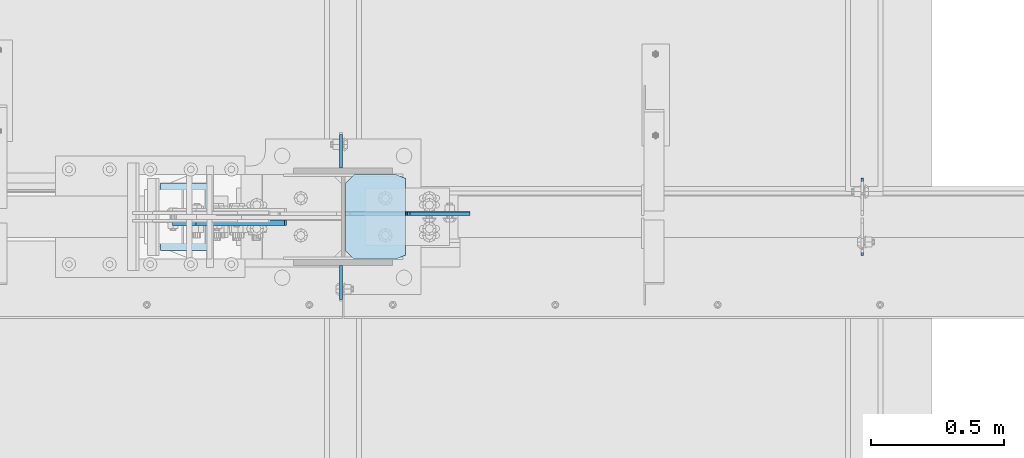
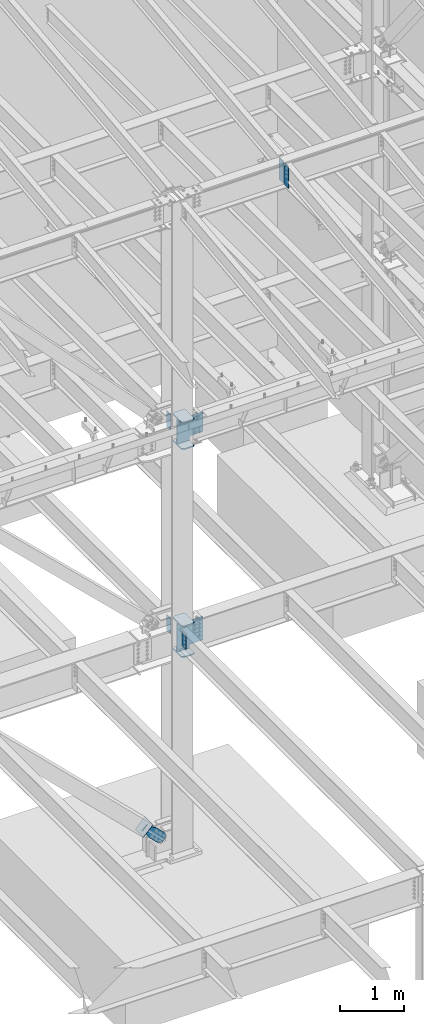
# One storey, part 1042 of 1179: 13 plates, 4 elements without a shape of their own.
"""IFC2X3 building model written with IfcOpenShell, lengths in millimetres."""

from ifc_helpers import new_model, si_unit, frame, origin_with_axes, place, context, subcontext, project, spatial, faceted_brep, material, type_object, element, aggregate, save


model = new_model("IFC2X3")

# Units and contexts
model_context = context("Model", 3, precision=1e-05, world=origin_with_axes())
body_context = subcontext(model_context, "Body", "Model", "MODEL_VIEW")
ifc_project = project(units=[si_unit("LENGTHUNIT", "METRE", prefix="MILLI"), si_unit("AREAUNIT", "SQUARE_METRE"), si_unit("VOLUMEUNIT", "CUBIC_METRE"), si_unit("MASSUNIT", "GRAM", prefix="KILO"), si_unit("TIMEUNIT", "SECOND"), si_unit("PLANEANGLEUNIT", "RADIAN"), si_unit("SOLIDANGLEUNIT", "STERADIAN"), si_unit("THERMODYNAMICTEMPERATUREUNIT", "DEGREE_CELSIUS"), si_unit("LUMINOUSINTENSITYUNIT", "LUMEN")], contexts=[model_context])

# Site, building, storey
site_placement = place(None, origin_with_axes())
site = spatial("IfcSite", under=ifc_project, at=site_placement, CompositionType="ELEMENT")
building_placement = place(site_placement, origin_with_axes())
building = spatial("IfcBuilding", under=site, at=building_placement, Name="Undefined", CompositionType="ELEMENT")
storey_placement = place(building_placement, origin_with_axes())
storey = spatial("IfcBuildingStorey", under=building, at=storey_placement, Name="Undefined", CompositionType="ELEMENT", Elevation=0.0)

# Assembly, plates
assembly_1_placement = place(storey_placement, origin_with_axes())
assembly_1 = element("IfcElementAssembly", 1, at=assembly_1_placement, inside=storey, Name="COLUMN", AssemblyPlace="NOTDEFINED", PredefinedType="RIGID_FRAME")
ifc_material_1 = material(Name="STEEL/A36")
plate_type_1 = type_object("IfcPlateType", PredefinedType="NOTDEFINED")
plate_1_placement = place(assembly_1_placement, frame((16451.2625, 27233.5625, 7975.59999886453), z_axis=(0.0, 1.0, 0.0), x_axis=(0.0, 0.0, -1.0)))
plate_1 = element("IfcPlate", 2, at=plate_1_placement, type_object=plate_type_1, material=ifc_material_1, Name="PLATE", context=body_context, shape_type="Brep", body=[
    faceted_brep([(0.0, -4.76249999999709, 0.0), (0.0, -4.76249999999709, 127.0), (0.0, 4.76249999999709, 127.0), (0.0, 4.76249999999709, 0.0), (304.799999999999, -4.76249999999982, 127.0), (304.799999999999, 4.76249999999982, 127.0), (304.799987792969, -4.76250000000073, 0.0), (304.799987792969, 4.76250000000073, 0.0)], [[[0, 1, 2, 3]], [[2, 1, 4, 5]], [[4, 6, 7, 5]], [[6, 0, 3, 7]], [[5, 7, 3, 2]], [[6, 4, 1, 0]]]),
])
plate_2_placement = place(assembly_1_placement, frame((16451.2625, 26868.4375, 4063.99999886453), z_axis=(0.0, -1.0, 0.0), x_axis=(0.0, 0.0, -1.0)))
plate_2 = element("IfcPlate", 3, at=plate_2_placement, type_object=plate_type_1, material=ifc_material_1, Name="PLATE", context=body_context, shape_type="Brep", body=[
    faceted_brep([(0.0, -4.76249999999709, 0.0), (0.0, -4.76249999999709, 127.0), (0.0, 4.76249999999709, 127.0), (0.0, 4.76249999999709, 0.0), (304.799999999999, -4.76249999999982, 127.0), (304.799999999999, 4.76249999999982, 127.0), (304.799987792969, -4.76250000000073, 0.0), (304.799987792969, 4.76250000000073, 0.0)], [[[0, 1, 2, 3]], [[2, 1, 4, 5]], [[4, 6, 7, 5]], [[6, 0, 3, 7]], [[5, 7, 3, 2]], [[6, 4, 1, 0]]]),
])
plate_3_placement = place(assembly_1_placement, frame((16451.2625, 27233.5625, 4063.99999886453), z_axis=(0.0, 1.0, 0.0), x_axis=(0.0, 0.0, -1.0)))
plate_3 = element("IfcPlate", 4, at=plate_3_placement, type_object=plate_type_1, material=ifc_material_1, Name="PLATE", context=body_context, shape_type="Brep", body=[
    faceted_brep([(0.0, -4.76249999999709, 0.0), (0.0, -4.76250000000073, 127.109008789062), (0.0, 4.76250000000073, 127.109008789062), (0.0, 4.76249999999709, 0.0), (304.799987792969, -4.76250000000073, 127.109008789062), (304.799987792969, 4.76250000000073, 127.109008789062), (304.799987792969, -4.76250000000073, 0.0), (304.799987792969, 4.76250000000073, 0.0)], [[[0, 1, 2, 3]], [[1, 4, 5, 2]], [[4, 6, 7, 5]], [[6, 0, 3, 7]], [[5, 7, 3, 2]], [[6, 4, 1, 0]]]),
])

assembly_2_placement = place(storey_placement, origin_with_axes())
assembly_2 = element("IfcElementAssembly", 5, at=assembly_2_placement, inside=storey, Name="BEAM", AssemblyPlace="NOTDEFINED", PredefinedType="RIGID_FRAME")
plate_type_2 = type_object("IfcPlateType", PredefinedType="NOTDEFINED")
plate_4_placement = place(assembly_2_placement, frame((18407.0620000839, 27045.4437499701, 11823.3031250357), z_axis=(0.0, 0.0, 1.0), x_axis=(0.0, -1.0, 0.0)))
plate_4 = element("IfcPlate", 6, at=plate_4_placement, type_object=plate_type_2, material=ifc_material_1, Name="PLATE", context=body_context, shape_type="Brep", body=[
    faceted_brep([(-1.81898940354586e-12, -4.76249999999345, 17.4624996185303), (0.0, -4.76250000000073, 407.98750038147), (0.0, 4.76250000000073, 407.98750038147), (1.81898940354586e-12, 4.76250000000073, 17.4624996185303), (17.4624996185303, -4.76250000000073, 425.450000000001), (17.4624996185303, 4.76250000000073, 425.450000000001), (139.699999999997, -4.76250000000073, 425.450000000001), (139.699999999997, 4.76250000000073, 425.450000000001), (139.7, -4.76249999999982, 0.0), (139.7, 4.76249999999982, 0.0), (17.4624996185157, -4.76250000000073, 0.0), (17.4624996185212, 4.76249999999345, 0.0)], [[[0, 1, 2, 3]], [[1, 4, 5, 2]], [[4, 6, 7, 5]], [[6, 8, 9, 7]], [[8, 10, 11, 9]], [[10, 0, 3, 11]], [[5, 7, 9, 11, 3, 2]], [[10, 8, 6, 4, 1, 0]]]),
])
plate_5_placement = place(assembly_2_placement, frame((18407.0620000839, 27056.5562499701, 11823.3031250357), z_axis=(0.0, 0.0, 1.0), x_axis=(0.0, 1.0, 0.0)))
plate_5 = element("IfcPlate", 7, at=plate_5_placement, type_object=plate_type_2, material=ifc_material_1, Name="PLATE", context=body_context, shape_type="Brep", body=[
    faceted_brep([(-1.81898940354586e-12, -4.76249999999345, 17.4624996185303), (0.0, -4.76250000000073, 407.98750038147), (0.0, 4.76250000000073, 407.98750038147), (1.81898940354586e-12, 4.76250000000073, 17.4624996185303), (17.4624996185303, -4.76250000000073, 425.450000000001), (17.4624996185303, 4.76250000000073, 425.450000000001), (139.699999999997, -4.76250000000073, 425.450000000001), (139.699999999997, 4.76250000000073, 425.450000000001), (139.7, -4.76249999999982, 0.0), (139.7, 4.76249999999982, 0.0), (17.4624996185157, -4.76250000000073, 0.0), (17.4624996185212, 4.76249999999345, 0.0)], [[[0, 1, 2, 3]], [[1, 4, 5, 2]], [[4, 6, 7, 5]], [[6, 8, 9, 7]], [[8, 10, 11, 9]], [[10, 0, 3, 11]], [[5, 7, 9, 11, 3, 2]], [[10, 8, 6, 4, 1, 0]]]),
])
aggregate(assembly_2, [plate_4, plate_5])

# Plate
ifc_material_2 = material(Name="STEEL/A572-GR.50")
plate_type_3 = type_object("IfcPlateType", PredefinedType="NOTDEFINED")
plate_6_placement = place(assembly_1_placement, frame((16694.15, 26892.25, 7491.4125), z_axis=(0.0, 1.0, 0.0), x_axis=(-1.0, 0.0, 0.0)))
plate_6 = element("IfcPlate", 8, at=plate_6_placement, type_object=plate_type_3, material=ifc_material_2, Name="PLATE", context=body_context, shape_type="Brep", body=[
    faceted_brep([(36.5125000000007, -11.1124999999993, 0.0), (0.0, -11.1124999999993, 14.6049999999996), (0.0, 11.1124999999993, 14.6049999999996), (36.5125000000007, 11.1124999999993, 0.0), (36.5125000000007, -11.1124999999993, 317.5), (36.5125000000007, 11.1124999999993, 317.5), (0.0, 11.1124999999993, 302.895), (0.0, -11.1124999999993, 302.895), (193.675000762942, -11.1124999999993, 317.5), (193.675000762942, 11.1124999999993, 317.5), (228.600000000002, -11.1124999999993, 282.575000762939), (228.600000000002, 11.1124999999993, 282.575000762939), (228.600000000002, -11.1124999999993, 34.9249992370605), (228.600000000002, 11.1124999999993, 34.9249992370605), (193.675000762942, -11.1124999999993, 0.0), (193.675000762942, 11.1124999999993, 0.0)], [[[0, 1, 2, 3]], [[4, 5, 6, 7]], [[8, 9, 5, 4]], [[8, 10, 11, 9]], [[10, 12, 13, 11]], [[12, 14, 15, 13]], [[15, 14, 0, 3]], [[6, 5, 9, 11, 13, 15, 3, 2]], [[7, 6, 2, 1]], [[14, 12, 10, 8, 4, 7, 1, 0]]]),
])

plate_7_placement = place(assembly_1_placement, frame((16694.15, 26892.25, 8002.5875), z_axis=(0.0, 1.0, 0.0), x_axis=(-1.0, 0.0, 0.0)))
plate_7 = element("IfcPlate", 9, at=plate_7_placement, type_object=plate_type_3, material=ifc_material_2, Name="PLATE", context=body_context, shape_type="Brep", body=[
    faceted_brep([(36.5125000000007, -11.1124999999993, 0.0), (0.0, -11.1124999999993, 14.6049999999996), (0.0, 11.1124999999993, 14.6049999999996), (36.5125000000007, 11.1124999999993, 0.0), (36.5125000000007, -11.1124999999993, 317.5), (36.5125000000007, 11.1124999999993, 317.5), (0.0, 11.1124999999993, 302.895), (0.0, -11.1124999999993, 302.895), (193.675000762942, -11.1124999999993, 317.5), (193.675000762942, 11.1124999999993, 317.5), (228.600000000002, -11.1124999999993, 282.575000762939), (228.600000000002, 11.1124999999993, 282.575000762939), (228.600000000002, -11.1124999999993, 34.9249992370605), (228.600000000002, 11.1124999999993, 34.9249992370605), (193.675000762942, -11.1124999999993, 0.0), (193.675000762942, 11.1124999999993, 0.0)], [[[0, 1, 2, 3]], [[4, 5, 6, 7]], [[8, 9, 5, 4]], [[8, 10, 11, 9]], [[10, 12, 13, 11]], [[12, 14, 15, 13]], [[15, 14, 0, 3]], [[6, 5, 9, 11, 13, 15, 3, 2]], [[7, 6, 2, 1]], [[14, 12, 10, 8, 4, 7, 1, 0]]]),
])

plate_8_placement = place(assembly_1_placement, frame((16694.15, 26892.25, 3500.4375), z_axis=(0.0, 1.0, 0.0), x_axis=(-1.0, 0.0, 0.0)))
plate_8 = element("IfcPlate", 10, at=plate_8_placement, type_object=plate_type_3, material=ifc_material_2, Name="PLATE", context=body_context, shape_type="Brep", body=[
    faceted_brep([(36.5125000000007, -11.1124999999993, 0.0), (0.0, -11.1125000000002, 14.979486697699), (0.0, 11.1125000000002, 14.979486697699), (36.5125000000007, 11.1124999999993, 0.0), (36.5125000000007, -11.1124999999993, 317.5), (36.5125000000007, 11.1124999999993, 317.5), (0.0, 11.1125000000002, 302.520512676303), (0.0, -11.1125000000002, 302.520512676303), (193.675000762942, -11.1124999999993, 317.5), (193.675000762942, 11.1124999999993, 317.5), (228.600000000002, -11.1124999999993, 282.575000762939), (228.600000000002, 11.1124999999993, 282.575000762939), (228.600000000002, -11.1124999999993, 34.9249992370605), (228.600000000002, 11.1124999999993, 34.9249992370605), (193.675000762942, -11.1124999999993, 0.0), (193.675000762942, 11.1124999999993, 0.0)], [[[0, 1, 2, 3]], [[4, 5, 6, 7]], [[8, 9, 5, 4]], [[8, 10, 11, 9]], [[10, 12, 13, 11]], [[12, 14, 15, 13]], [[15, 14, 0, 3]], [[6, 5, 9, 11, 13, 15, 3, 2]], [[7, 6, 2, 1]], [[14, 12, 10, 8, 4, 7, 1, 0]]]),
])

plate_9_placement = place(assembly_1_placement, frame((16694.15, 26892.25, 4090.9875), z_axis=(0.0, 1.0, 0.0), x_axis=(-1.0, 0.0, 0.0)))
plate_9 = element("IfcPlate", 11, at=plate_9_placement, type_object=plate_type_3, material=ifc_material_2, Name="PLATE", context=body_context, shape_type="Brep", body=[
    faceted_brep([(38.0999999999985, -11.1125000000002, 0.0), (0.0, -11.1125000000002, 15.2399997711182), (0.0, 11.1125000000002, 15.2399997711182), (38.0999999999985, 11.1125000000002, 0.0), (37.4487188716666, -11.1125000000002, 317.5), (37.4487188716666, 11.1125000000002, 317.5), (0.0, 11.1125000000002, 302.520512676303), (0.0, -11.1125000000002, 302.520512676303), (193.675000762942, -11.1124999999993, 317.5), (193.675000762942, 11.1124999999993, 317.5), (228.600000000002, -11.1124999999993, 282.575000762939), (228.600000000002, 11.1124999999993, 282.575000762939), (228.600000000002, -11.1124999999993, 34.9249992370605), (228.600000000002, 11.1124999999993, 34.9249992370605), (193.675000762942, -11.1124999999993, 0.0), (193.675000762942, 11.1124999999993, 0.0)], [[[0, 1, 2, 3]], [[4, 5, 6, 7]], [[8, 9, 5, 4]], [[8, 10, 11, 9]], [[10, 12, 13, 11]], [[12, 14, 15, 13]], [[15, 14, 0, 3]], [[6, 5, 9, 11, 13, 15, 3, 2]], [[7, 6, 2, 1]], [[14, 12, 10, 8, 4, 7, 1, 0]]]),
])

plate_type_4 = type_object("IfcPlateType", PredefinedType="NOTDEFINED")
plate_10_placement = place(assembly_1_placement, frame((16465.5499993954, 27062.1125, 7521.575), z_axis=(0.707106781186573, 0.0, 0.707106781186522), x_axis=(0.707106781186522, 0.0, -0.707106781186573)))
plate_10 = element("IfcPlate", 12, at=plate_10_placement, type_object=plate_type_4, material=ifc_material_2, Name="PLATE", context=body_context, shape_type="Brep", body=[
    faceted_brep([(0.0, -6.34999999999854, 0.0), (-318.799092298076, -6.34999999999854, 318.799092298053), (-318.799092298076, 6.34999999999854, 318.799092298053), (0.0, 6.34999999999854, 0.0), (-318.799092298147, -6.34999999999854, 345.739860661201), (-318.799092298147, 6.34999999999854, 345.739860661201), (-170.624866301226, -6.34999999999854, 493.914086658137), (-170.624866301226, 6.34999999999854, 493.914086658137), (-168.379802001214, -6.34999999999854, 491.669022358128), (-168.379802001214, 6.34999999999854, 491.669022358128), (-160.139449064909, -6.34999999999854, 486.162994557169), (-160.139449064909, 6.34999999999854, 486.162994557169), (-150.419290028824, -6.34999999999854, 484.229534711983), (-150.419290028824, 6.34999999999854, 484.229534711983), (-140.699130992749, -6.34999999999854, 486.162994557144), (-140.699130992749, 6.34999999999854, 486.162994557144), (-132.458778056457, -6.34999999999854, 491.669022358081), (-132.458778056457, 6.34999999999854, 491.669022358081), (20.2055762706732, -6.34999999999854, 644.333376685223), (20.2055762706732, 6.34999999999854, 644.333376685223), (289.613259902851, -6.34999999999854, 374.925693053072), (289.613259902851, 6.34999999999854, 374.925693053072), (136.948905575722, -6.34999999999854, 222.261338725926), (136.948905575722, 6.34999999999854, 222.261338725926), (131.442877774783, -6.34999999999854, 214.020985789637), (131.442877774783, 6.34999999999854, 214.020985789637), (129.509417929622, -6.34999999999854, 204.300826753559), (129.509417929622, 6.34999999999854, 204.300826753559), (131.442877774809, -6.34999999999854, 194.580667717477), (131.442877774809, 6.34999999999854, 194.580667717477), (136.948905575769, -6.34999999999854, 186.340314781173), (136.948905575769, 6.34999999999854, 186.340314781173), (175.114994360907, -6.34999999999854, 148.174225997692), (175.114994360907, 6.34999999999854, 148.174225997692), (26.9407683631471, -6.34999999999854, -6.91215973347425e-11), (26.9407683631471, 6.34999999999854, -6.91215973347425e-11)], [[[0, 1, 2, 3]], [[1, 4, 5, 2]], [[4, 6, 7, 5]], [[6, 8, 9, 7]], [[8, 10, 11, 9]], [[10, 12, 13, 11]], [[12, 14, 15, 13]], [[14, 16, 17, 15]], [[16, 18, 19, 17]], [[18, 20, 21, 19]], [[20, 22, 23, 21]], [[22, 24, 25, 23]], [[24, 26, 27, 25]], [[26, 28, 29, 27]], [[28, 30, 31, 29]], [[30, 32, 33, 31]], [[32, 34, 35, 33]], [[34, 0, 3, 35]], [[5, 7, 9, 11, 13, 15, 17, 19, 21, 23, 25, 27, 29, 31, 33, 35, 3, 2]], [[34, 32, 30, 28, 26, 24, 22, 20, 18, 16, 14, 12, 10, 8, 6, 4, 1, 0]]]),
])

plate_11_placement = place(assembly_1_placement, frame((16465.550001312, 27063.7, 3530.6), z_axis=(0.707106781186573, 0.0, 0.707106781186522), x_axis=(0.707106781186522, 0.0, -0.707106781186573)))
plate_11 = element("IfcPlate", 13, at=plate_11_placement, type_object=plate_type_4, material=ifc_material_2, Name="PLATE", context=body_context, shape_type="Brep", body=[
    faceted_brep([(0.0, -6.34999999999854, 0.0), (-374.925693054754, -6.34999999999854, 374.925693054773), (-374.925693054754, 6.34999999999854, 374.925693054773), (0.0, 6.34999999999854, 0.0), (-374.925693054789, -6.34999999999854, 401.866461417955), (-374.925693054789, 6.34999999999854, 401.866461417955), (-226.751467057473, -6.34999999999854, 550.040687415264), (-226.751467057473, 6.34999999999854, 550.040687415264), (-215.52614663639, -6.34999999999854, 538.815366994181), (-215.52614663639, 6.34999999999854, 538.815366994181), (-207.285793700081, -6.34999999999854, 533.309339193224), (-207.285793700081, 6.34999999999854, 533.309339193224), (-197.565634663988, -6.34999999999854, 531.375879348047), (-197.565634663988, 6.34999999999854, 531.375879348047), (-187.845475627895, -6.34999999999854, 533.309339193224), (-187.845475627895, 6.34999999999854, 533.309339193224), (-179.605122691586, -6.34999999999854, 538.81536699418), (-179.605122691586, 6.34999999999854, 538.81536699418), (-26.9407683640547, -6.34999999999854, 691.479721321704), (-26.9407683640547, 6.34999999999854, 691.479721321704), (296.348451994538, -6.34999999999854, 368.190500963096), (296.348451994538, 6.34999999999854, 368.190500963096), (143.684097667006, -6.34999999999854, 215.526146635572), (143.684097667006, 6.34999999999854, 215.526146635572), (138.178069866048, -6.34999999999854, 207.285793699265), (138.178069866048, 6.34999999999854, 207.285793699265), (136.244610020873, -6.34999999999854, 197.565634663171), (136.244610020873, 6.34999999999854, 197.565634663171), (138.178069866048, -6.34999999999854, 187.845475627078), (138.178069866048, 6.34999999999854, 187.845475627078), (143.684097667005, -6.34999999999854, 179.605122690769), (143.684097667005, 6.34999999999854, 179.605122690769), (175.114994360907, -6.34999999999854, 148.174225997692), (175.114994360907, 6.34999999999854, 148.174225997692), (26.9407683631471, -6.34999999999854, -6.91215973347425e-11), (26.9407683631471, 6.34999999999854, -6.91215973347425e-11)], [[[0, 1, 2, 3]], [[1, 4, 5, 2]], [[4, 6, 7, 5]], [[6, 8, 9, 7]], [[8, 10, 11, 9]], [[10, 12, 13, 11]], [[12, 14, 15, 13]], [[14, 16, 17, 15]], [[16, 18, 19, 17]], [[18, 20, 21, 19]], [[20, 22, 23, 21]], [[22, 24, 25, 23]], [[24, 26, 27, 25]], [[26, 28, 29, 27]], [[28, 30, 31, 29]], [[30, 32, 33, 31]], [[32, 34, 35, 33]], [[34, 0, 3, 35]], [[5, 7, 9, 11, 13, 15, 17, 19, 21, 23, 25, 27, 29, 31, 33, 35, 3, 2]], [[34, 32, 30, 28, 26, 24, 22, 20, 18, 16, 14, 12, 10, 8, 6, 4, 1, 0]]]),
])

aggregate(assembly_1, [plate_1, plate_6, plate_7, plate_10, plate_8, plate_9, plate_11, plate_2, plate_3])

# Assembly, plate
assembly_3_placement = place(storey_placement, origin_with_axes())
assembly_3 = element("IfcElementAssembly", 14, at=assembly_3_placement, inside=storey, AssemblyPlace="NOTDEFINED", PredefinedType="RIGID_FRAME")
plate_type_5 = type_object("IfcPlateType", PredefinedType="NOTDEFINED")
plate_12_placement = place(assembly_3_placement, frame((15907.5429418252, 27028.775, 413.540432750507), z_axis=(-0.699860687134476, 0.0, -0.714279370137245), x_axis=(0.714279370137245, 0.0, -0.699860687134476)))
plate_12 = element("IfcPlate", 15, at=plate_12_placement, type_object=plate_type_5, material=ifc_material_1, context=body_context, shape_type="Brep", body=[
    faceted_brep([(0.0, -9.52499999999964, 0.0), (-5.72072167415172e-10, -9.52500000000146, 127.026455577978), (-5.72072167415172e-10, 9.52500000000146, 127.026455577978), (0.0, 9.52499999999964, 0.0), (82.5499999996218, -9.52500000000146, 127.02645557804), (82.5499999996218, 9.52500000000146, 127.02645557804), (184.149999999816, -9.52500000000146, 160.350727789162), (184.149999999816, 9.52500000000146, 160.350727789162), (402.829297671884, -9.52500000000146, 160.350727789319), (402.829297671884, 9.52500000000146, 160.350727789319), (439.887405137379, -9.52500000000146, 152.97941190279), (439.887405137379, 9.52500000000146, 152.97941190279), (471.303751673868, -9.52500000000146, 131.987680265722), (471.303751673868, 9.52500000000146, 131.987680265722), (492.295483311087, -9.52500000000146, 100.571333729322), (492.295483311087, 9.52500000000146, 100.571333729322), (499.666799197799, -9.52500000000146, 63.5132293155057), (499.666799197799, 9.52500000000146, 63.5132293155057), (492.295483311342, -9.52500000000146, 26.4551218498), (492.295483311342, 9.52500000000146, 26.4551218498), (471.303751674215, -9.52500000000146, -4.96122468687645), (471.303751674215, 9.52500000000146, -4.96122468687645), (439.887405137664, -9.52500000000146, -25.9529563241722), (439.887405137664, 9.52500000000146, -25.9529563241722), (402.829299197954, -9.52500000000146, -33.3242722108225), (402.829299197954, 9.52500000000146, -33.3242722108225), (184.150000000667, -9.52500000000146, -33.324272210979), (184.150000000667, 9.52500000000146, -33.324272210979), (82.5499999997119, -9.52500000000146, 1.81898940354586e-11), (82.5499999997119, 9.52500000000146, 1.81898940354586e-11)], [[[0, 1, 2, 3]], [[1, 4, 5, 2]], [[4, 6, 7, 5]], [[6, 8, 9, 7]], [[8, 10, 11, 9]], [[10, 12, 13, 11]], [[12, 14, 15, 13]], [[14, 16, 17, 15]], [[16, 18, 19, 17]], [[18, 20, 21, 19]], [[20, 22, 23, 21]], [[22, 24, 25, 23]], [[24, 26, 27, 25]], [[26, 28, 29, 27]], [[28, 0, 3, 29]], [[5, 7, 9, 11, 13, 15, 17, 19, 21, 23, 25, 27, 29, 3, 2]], [[28, 26, 24, 22, 20, 18, 16, 14, 12, 10, 8, 6, 4, 1, 0]]]),
])
aggregate(assembly_3, [plate_12])

assembly_4_placement = place(storey_placement, origin_with_axes())
assembly_4 = element("IfcElementAssembly", 16, at=assembly_4_placement, inside=storey, Name="Plate", AssemblyPlace="NOTDEFINED", PredefinedType="RIGID_FRAME")
plate_type_6 = type_object("IfcPlateType", PredefinedType="NOTDEFINED")
plate_13_placement = place(assembly_4_placement, frame((15776.4780603142, 27178.0, 275.238706720427), z_axis=(0.699860687134476, 0.0, 0.714279370137245), x_axis=(0.0, -1.0, 0.0)))
plate_13 = element("IfcPlate", 17, at=plate_13_placement, type_object=plate_type_6, material=ifc_material_1, Name="Plate", context=body_context, shape_type="Brep", body=[
    faceted_brep([(0.0, -3.17500000000109, 0.0), (0.0, -3.17499999986103, 253.99999999967), (0.0, 3.17500000013752, 253.999999999668), (0.0, 3.17500000000109, 7.27595761418343e-12), (254.0, -3.17499999986103, 253.99999999967), (254.0, 3.17500000013752, 253.999999999668), (254.0, -3.17500000000109, 9.09494701772928e-13), (254.0, 3.17499999999745, -1.36424205265939e-12)], [[[0, 1, 2, 3]], [[1, 4, 5, 2]], [[4, 6, 7, 5]], [[6, 0, 3, 7]], [[5, 7, 3, 2]], [[6, 4, 1, 0]]]),
])
aggregate(assembly_4, [plate_13])

save(model, "model.ifc")
